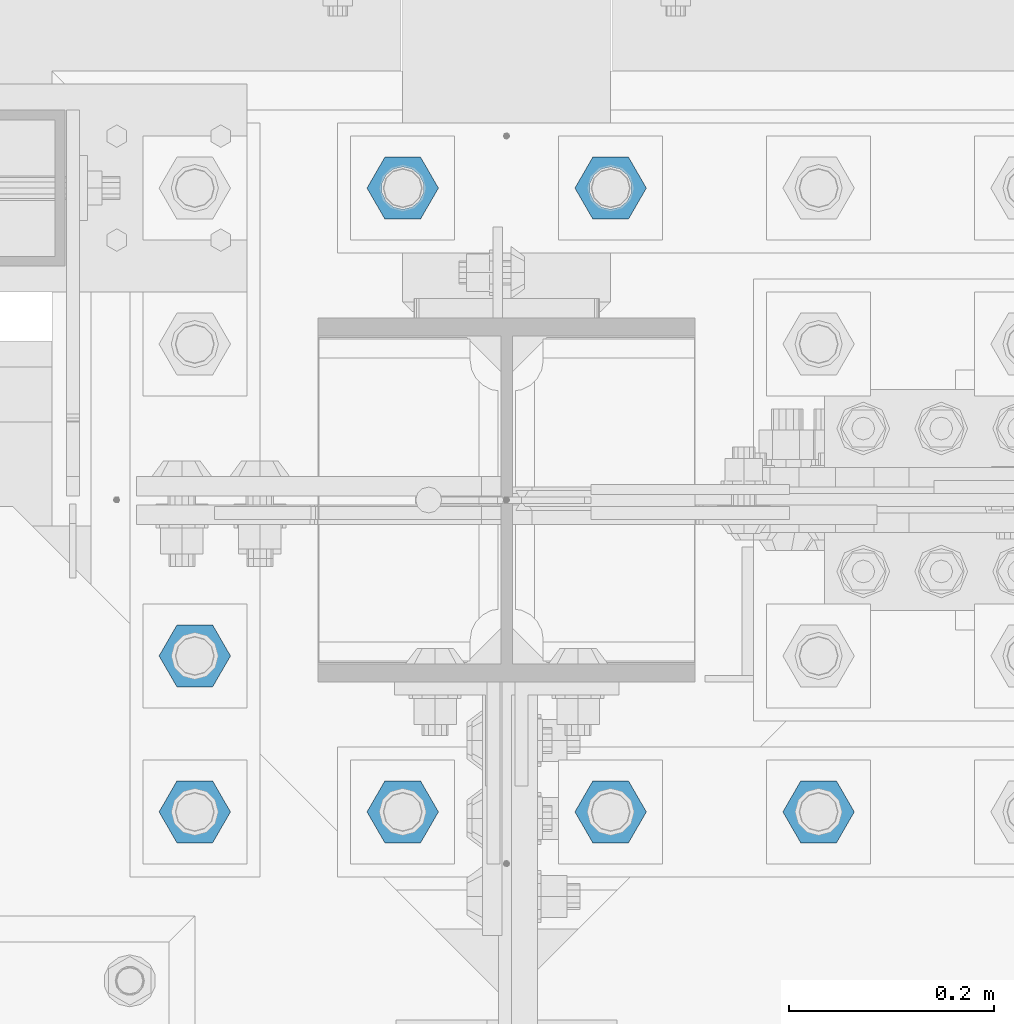
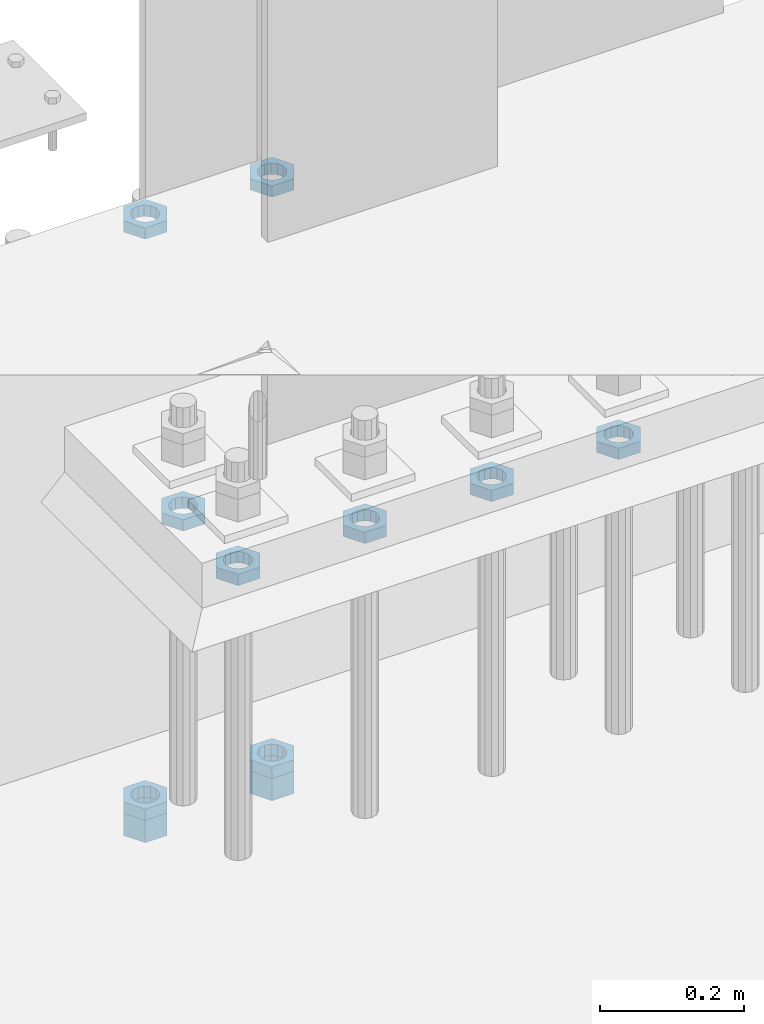
# One storey, part 2878 of 3843: 11 beams, 1 element without a shape of its own.
"""IFC2X3 building model written with IfcOpenShell, lengths in millimetres."""

from ifc_helpers import new_model, si_unit, frame, origin_with_axes, place, context, subcontext, project, spatial, faceted_brep, material, type_object, element, aggregate, save


model = new_model("IFC2X3")

# Units and contexts
model_context = context("Model", 3, precision=1e-05, world=origin_with_axes())
body_context = subcontext(model_context, "Body", "Model", "MODEL_VIEW")
ifc_project = project(units=[si_unit("LENGTHUNIT", "METRE", prefix="MILLI"), si_unit("AREAUNIT", "SQUARE_METRE"), si_unit("VOLUMEUNIT", "CUBIC_METRE"), si_unit("MASSUNIT", "GRAM", prefix="KILO"), si_unit("TIMEUNIT", "SECOND"), si_unit("PLANEANGLEUNIT", "RADIAN"), si_unit("SOLIDANGLEUNIT", "STERADIAN"), si_unit("THERMODYNAMICTEMPERATUREUNIT", "DEGREE_CELSIUS"), si_unit("LUMINOUSINTENSITYUNIT", "LUMEN")], contexts=[model_context])

# Site, building, storey
site_placement = place(None, origin_with_axes())
site = spatial("IfcSite", under=ifc_project, at=site_placement, CompositionType="ELEMENT")
building_placement = place(site_placement, origin_with_axes())
building = spatial("IfcBuilding", under=site, at=building_placement, Name="Undefined", CompositionType="ELEMENT")
storey_placement = place(building_placement, origin_with_axes())
storey = spatial("IfcBuildingStorey", under=building, at=storey_placement, Name="Undefined", CompositionType="ELEMENT", Elevation=0.0)

# Assembly, beams
assembly_placement = place(storey_placement, origin_with_axes())
assembly = element("IfcElementAssembly", 1, at=assembly_placement, inside=storey, Name="TEMPLATE", AssemblyPlace="NOTDEFINED", PredefinedType="RIGID_FRAME")
ifc_material = material(Name="STEEL/A572-50")
beam_type_1 = type_object("IfcBeamType", Name="1-1/2_HEAVY_HEX_NUT", PredefinedType="NOTDEFINED")
beam_1_placement = place(assembly_placement, frame((48895.0, 92519.5, 29203.6500015259), z_axis=(0.0, -1.0, 0.0), x_axis=(0.0, 0.0, -1.0)))
beam_1 = element("IfcBeam", 2, at=beam_1_placement, type_object=beam_type_1, material=ifc_material, Name="NUT", ObjectType="1-1/2_HEAVY_HEX_NUT", context=body_context, shape_type="Brep", body=[
    faceted_brep([(0.0, -34.9199981689453, 0.0), (0.0, -17.4599990844727, -30.25), (38.0999999999985, -17.4599990844727, -30.25), (38.0999999999985, -34.9199981689453, 0.0), (0.0, 17.4599990844727, -30.25), (38.0999999999985, 17.4599990844727, -30.25), (0.0, 34.9199981689453, 0.0), (38.0999999999985, 34.9199981689453, 0.0), (0.0, 17.4599990844727, 30.25), (38.0999999999985, 17.4599990844727, 30.25), (0.0, -17.4599990844727, 30.25), (38.0999999999985, -17.4599990844727, 30.25), (0.0, 0.0, 20.6399993896484), (0.0, 8.9553601105581, 18.5959968835959), (38.0999999999985, 8.9553601105581, 18.5959968835959), (38.0999999999985, 0.0, 20.6399993896484), (0.0, 16.1370013209525, 12.8688291298167), (38.0999999999985, 16.1370013209525, 12.8688291298167), (0.0, 20.1225115123816, 4.59283194104501), (38.0999999999985, 20.1225115123816, 4.59283194104501), (0.0, 20.1225115123816, -4.59283194104501), (38.0999999999985, 20.1225115123816, -4.59283194104501), (0.0, 16.1370013209525, -12.8688291298167), (38.0999999999985, 16.1370013209525, -12.8688291298167), (0.0, 8.9553601105581, -18.5959968835959), (38.0999999999985, 8.9553601105581, -18.5959968835959), (0.0, 0.0, -20.6399993896484), (38.0999999999985, 0.0, -20.6399993896484), (0.0, -8.9553601105581, -18.5959968835959), (38.0999999999985, -8.9553601105581, -18.5959968835959), (0.0, -16.1370013209525, -12.8688291298167), (38.0999999999985, -16.1370013209525, -12.8688291298167), (0.0, -20.1225115123816, -4.59283194104501), (38.0999999999985, -20.1225115123816, -4.59283194104501), (0.0, -20.1225115123816, 4.59283194104501), (38.0999999999985, -20.1225115123816, 4.59283194104501), (0.0, -16.1370013209525, 12.8688291298167), (38.0999999999985, -16.1370013209525, 12.8688291298167), (0.0, -8.9553601105581, 18.5959968835959), (38.0999999999985, -8.9553601105581, 18.5959968835959)], [[[0, 1, 2, 3]], [[1, 4, 5, 2]], [[4, 6, 7, 5]], [[6, 8, 9, 7]], [[8, 10, 11, 9]], [[10, 0, 3, 11]], [[12, 13, 14, 15]], [[13, 16, 17, 14]], [[16, 18, 19, 17]], [[18, 20, 21, 19]], [[20, 22, 23, 21]], [[22, 24, 25, 23]], [[24, 26, 27, 25]], [[26, 28, 29, 27]], [[28, 30, 31, 29]], [[30, 32, 33, 31]], [[32, 34, 35, 33]], [[34, 36, 37, 35]], [[36, 38, 39, 37]], [[38, 12, 15, 39]], [[5, 7, 9, 11, 3, 2], [17, 19, 21, 23, 25, 27, 29, 31, 33, 35, 37, 39, 15, 14]], [[10, 8, 6, 4, 1, 0], [38, 36, 34, 32, 30, 28, 26, 24, 22, 20, 18, 16, 13, 12]]]),
])
beam_2_placement = place(assembly_placement, frame((49098.2, 92519.5, 29203.6500015259), z_axis=(0.0, -1.0, 0.0), x_axis=(0.0, 0.0, -1.0)))
beam_2 = element("IfcBeam", 3, at=beam_2_placement, type_object=beam_type_1, material=ifc_material, Name="NUT", ObjectType="1-1/2_HEAVY_HEX_NUT", context=body_context, shape_type="Brep", body=[
    faceted_brep([(0.0, -34.9199981689453, 0.0), (0.0, -17.4599990844727, -30.25), (38.0999999999985, -17.4599990844727, -30.25), (38.0999999999985, -34.9199981689453, 0.0), (0.0, 17.4599990844727, -30.25), (38.0999999999985, 17.4599990844727, -30.25), (0.0, 34.9199981689453, 0.0), (38.0999999999985, 34.9199981689453, 0.0), (0.0, 17.4599990844727, 30.25), (38.0999999999985, 17.4599990844727, 30.25), (0.0, -17.4599990844727, 30.25), (38.0999999999985, -17.4599990844727, 30.25), (0.0, 0.0, 20.6399993896484), (0.0, 8.9553601105581, 18.5959968835959), (38.0999999999985, 8.9553601105581, 18.5959968835959), (38.0999999999985, 0.0, 20.6399993896484), (0.0, 16.1370013209525, 12.8688291298167), (38.0999999999985, 16.1370013209525, 12.8688291298167), (0.0, 20.1225115123816, 4.59283194104501), (38.0999999999985, 20.1225115123816, 4.59283194104501), (0.0, 20.1225115123816, -4.59283194104501), (38.0999999999985, 20.1225115123816, -4.59283194104501), (0.0, 16.1370013209525, -12.8688291298167), (38.0999999999985, 16.1370013209525, -12.8688291298167), (0.0, 8.9553601105581, -18.5959968835959), (38.0999999999985, 8.9553601105581, -18.5959968835959), (0.0, 0.0, -20.6399993896484), (38.0999999999985, 0.0, -20.6399993896484), (0.0, -8.9553601105581, -18.5959968835959), (38.0999999999985, -8.9553601105581, -18.5959968835959), (0.0, -16.1370013209525, -12.8688291298167), (38.0999999999985, -16.1370013209525, -12.8688291298167), (0.0, -20.1225115123816, -4.59283194104501), (38.0999999999985, -20.1225115123816, -4.59283194104501), (0.0, -20.1225115123816, 4.59283194104501), (38.0999999999985, -20.1225115123816, 4.59283194104501), (0.0, -16.1370013209525, 12.8688291298167), (38.0999999999985, -16.1370013209525, 12.8688291298167), (0.0, -8.9553601105581, 18.5959968835959), (38.0999999999985, -8.9553601105581, 18.5959968835959)], [[[0, 1, 2, 3]], [[1, 4, 5, 2]], [[4, 6, 7, 5]], [[6, 8, 9, 7]], [[8, 10, 11, 9]], [[10, 0, 3, 11]], [[12, 13, 14, 15]], [[13, 16, 17, 14]], [[16, 18, 19, 17]], [[18, 20, 21, 19]], [[20, 22, 23, 21]], [[22, 24, 25, 23]], [[24, 26, 27, 25]], [[26, 28, 29, 27]], [[28, 30, 31, 29]], [[30, 32, 33, 31]], [[32, 34, 35, 33]], [[34, 36, 37, 35]], [[36, 38, 39, 37]], [[38, 12, 15, 39]], [[5, 7, 9, 11, 3, 2], [17, 19, 21, 23, 25, 27, 29, 31, 33, 35, 37, 39, 15, 14]], [[10, 8, 6, 4, 1, 0], [38, 36, 34, 32, 30, 28, 26, 24, 22, 20, 18, 16, 13, 12]]]),
])
beam_type_2 = type_object("IfcBeamType", Name="1-1/2_HALF_NUT", PredefinedType="NOTDEFINED")
beam_3_placement = place(assembly_placement, frame((48691.800012207, 92062.3, 30060.9), z_axis=(0.0, -1.0, 0.0), x_axis=(0.0, 0.0, -1.0)))
beam_3 = element("IfcBeam", 4, at=beam_3_placement, type_object=beam_type_2, material=ifc_material, Name="NUT", ObjectType="1-1/2_HALF_NUT", context=body_context, shape_type="Brep", body=[
    faceted_brep([(0.0, -34.9199981689453, 0.0), (0.0, -17.4599990844727, -30.25), (19.0500000000029, -17.4599990844727, -30.25), (19.0500000000029, -34.9199981689453, 0.0), (0.0, 17.4599990844727, -30.25), (19.0500000000029, 17.4599990844727, -30.25), (0.0, 34.9199981689453, 0.0), (19.0500000000029, 34.9199981689453, 0.0), (0.0, 17.4599990844727, 30.25), (19.0500000000029, 17.4599990844727, 30.25), (0.0, -17.4599990844727, 30.25), (19.0500000000029, -17.4599990844727, 30.25), (0.0, 0.0, 20.6399993896484), (0.0, 8.9553601105581, 18.5959968835959), (19.0500000000029, 8.95536011056538, 18.5959968835959), (19.0500000000029, 0.0, 20.6399993896484), (0.0, 16.1370013209525, 12.8688291298167), (19.0500000000029, 16.1370013209489, 12.8688291298167), (0.0, 20.1225115123816, 4.59283194104501), (19.0500000000029, 20.1225115123852, 4.59283194104501), (0.0, 20.1225115123816, -4.59283194104501), (19.0500000000029, 20.1225115123852, -4.59283194104501), (0.0, 16.1370013209525, -12.8688291298167), (19.0500000000029, 16.1370013209489, -12.8688291298167), (0.0, 8.9553601105581, -18.5959968835959), (19.0500000000029, 8.95536011056538, -18.5959968835959), (0.0, 0.0, -20.6399993896484), (19.0500000000029, 0.0, -20.6399993896484), (0.0, -8.9553601105581, -18.5959968835959), (19.0500000000029, -8.95536011056538, -18.5959968835959), (0.0, -16.1370013209525, -12.8688291298167), (19.0500000000029, -16.1370013209489, -12.8688291298167), (0.0, -20.1225115123816, -4.59283194104501), (19.0500000000029, -20.1225115123852, -4.59283194104501), (0.0, -20.1225115123816, 4.59283194104501), (19.0500000000029, -20.1225115123852, 4.59283194104501), (0.0, -16.1370013209525, 12.8688291298167), (19.0500000000029, -16.1370013209489, 12.8688291298167), (0.0, -8.9553601105581, 18.5959968835959), (19.0500000000029, -8.95536011056538, 18.5959968835959)], [[[0, 1, 2, 3]], [[1, 4, 5, 2]], [[4, 6, 7, 5]], [[6, 8, 9, 7]], [[8, 10, 11, 9]], [[10, 0, 3, 11]], [[12, 13, 14, 15]], [[13, 16, 17, 14]], [[16, 18, 19, 17]], [[18, 20, 21, 19]], [[20, 22, 23, 21]], [[22, 24, 25, 23]], [[24, 26, 27, 25]], [[26, 28, 29, 27]], [[28, 30, 31, 29]], [[30, 32, 33, 31]], [[32, 34, 35, 33]], [[34, 36, 37, 35]], [[36, 38, 39, 37]], [[38, 12, 15, 39]], [[5, 7, 9, 11, 3, 2], [17, 19, 21, 23, 25, 27, 29, 31, 33, 35, 37, 39, 15, 14]], [[10, 8, 6, 4, 1, 0], [38, 36, 34, 32, 30, 28, 26, 24, 22, 20, 18, 16, 13, 12]]]),
])
beam_4_placement = place(assembly_placement, frame((48691.800012207, 91909.9, 30060.9), z_axis=(0.0, -1.0, 0.0), x_axis=(0.0, 0.0, -1.0)))
beam_4 = element("IfcBeam", 5, at=beam_4_placement, type_object=beam_type_2, material=ifc_material, Name="NUT", ObjectType="1-1/2_HALF_NUT", context=body_context, shape_type="Brep", body=[
    faceted_brep([(0.0, -34.9199981689453, 0.0), (0.0, -17.4599990844727, -30.25), (19.0500000000029, -17.4599990844727, -30.25), (19.0500000000029, -34.9199981689453, 0.0), (0.0, 17.4599990844727, -30.25), (19.0500000000029, 17.4599990844727, -30.25), (0.0, 34.9199981689453, 0.0), (19.0500000000029, 34.9199981689453, 0.0), (0.0, 17.4599990844727, 30.25), (19.0500000000029, 17.4599990844727, 30.25), (0.0, -17.4599990844727, 30.25), (19.0500000000029, -17.4599990844727, 30.25), (0.0, 0.0, 20.6399993896484), (0.0, 8.9553601105581, 18.5959968835959), (19.0500000000029, 8.95536011056538, 18.5959968835959), (19.0500000000029, 0.0, 20.6399993896484), (0.0, 16.1370013209525, 12.8688291298167), (19.0500000000029, 16.1370013209489, 12.8688291298167), (0.0, 20.1225115123816, 4.59283194104501), (19.0500000000029, 20.1225115123852, 4.59283194104501), (0.0, 20.1225115123816, -4.59283194104501), (19.0500000000029, 20.1225115123852, -4.59283194104501), (0.0, 16.1370013209525, -12.8688291298167), (19.0500000000029, 16.1370013209489, -12.8688291298167), (0.0, 8.9553601105581, -18.5959968835959), (19.0500000000029, 8.95536011056538, -18.5959968835959), (0.0, 0.0, -20.6399993896484), (19.0500000000029, 0.0, -20.6399993896484), (0.0, -8.9553601105581, -18.5959968835959), (19.0500000000029, -8.95536011056538, -18.5959968835959), (0.0, -16.1370013209525, -12.8688291298167), (19.0500000000029, -16.1370013209489, -12.8688291298167), (0.0, -20.1225115123816, -4.59283194104501), (19.0500000000029, -20.1225115123852, -4.59283194104501), (0.0, -20.1225115123816, 4.59283194104501), (19.0500000000029, -20.1225115123852, 4.59283194104501), (0.0, -16.1370013209525, 12.8688291298167), (19.0500000000029, -16.1370013209489, 12.8688291298167), (0.0, -8.9553601105581, 18.5959968835959), (19.0500000000029, -8.95536011056538, 18.5959968835959)], [[[0, 1, 2, 3]], [[1, 4, 5, 2]], [[4, 6, 7, 5]], [[6, 8, 9, 7]], [[8, 10, 11, 9]], [[10, 0, 3, 11]], [[12, 13, 14, 15]], [[13, 16, 17, 14]], [[16, 18, 19, 17]], [[18, 20, 21, 19]], [[20, 22, 23, 21]], [[22, 24, 25, 23]], [[24, 26, 27, 25]], [[26, 28, 29, 27]], [[28, 30, 31, 29]], [[30, 32, 33, 31]], [[32, 34, 35, 33]], [[34, 36, 37, 35]], [[36, 38, 39, 37]], [[38, 12, 15, 39]], [[5, 7, 9, 11, 3, 2], [17, 19, 21, 23, 25, 27, 29, 31, 33, 35, 37, 39, 15, 14]], [[10, 8, 6, 4, 1, 0], [38, 36, 34, 32, 30, 28, 26, 24, 22, 20, 18, 16, 13, 12]]]),
])
beam_5_placement = place(assembly_placement, frame((48895.000012207, 91909.9, 30060.9), z_axis=(0.0, -1.0, 0.0), x_axis=(0.0, 0.0, -1.0)))
beam_5 = element("IfcBeam", 6, at=beam_5_placement, type_object=beam_type_2, material=ifc_material, Name="NUT", ObjectType="1-1/2_HALF_NUT", context=body_context, shape_type="Brep", body=[
    faceted_brep([(0.0, -34.9199981689453, 0.0), (0.0, -17.4599990844727, -30.25), (19.0500000000029, -17.4599990844727, -30.25), (19.0500000000029, -34.9199981689453, 0.0), (0.0, 17.4599990844727, -30.25), (19.0500000000029, 17.4599990844727, -30.25), (0.0, 34.9199981689453, 0.0), (19.0500000000029, 34.9199981689453, 0.0), (0.0, 17.4599990844727, 30.25), (19.0500000000029, 17.4599990844727, 30.25), (0.0, -17.4599990844727, 30.25), (19.0500000000029, -17.4599990844727, 30.25), (0.0, 0.0, 20.6399993896484), (0.0, 8.9553601105581, 18.5959968835959), (19.0500000000029, 8.95536011056538, 18.5959968835959), (19.0500000000029, 0.0, 20.6399993896484), (0.0, 16.1370013209525, 12.8688291298167), (19.0500000000029, 16.1370013209489, 12.8688291298167), (0.0, 20.1225115123816, 4.59283194104501), (19.0500000000029, 20.1225115123852, 4.59283194104501), (0.0, 20.1225115123816, -4.59283194104501), (19.0500000000029, 20.1225115123852, -4.59283194104501), (0.0, 16.1370013209525, -12.8688291298167), (19.0500000000029, 16.1370013209489, -12.8688291298167), (0.0, 8.9553601105581, -18.5959968835959), (19.0500000000029, 8.95536011056538, -18.5959968835959), (0.0, 0.0, -20.6399993896484), (19.0500000000029, 0.0, -20.6399993896484), (0.0, -8.9553601105581, -18.5959968835959), (19.0500000000029, -8.95536011056538, -18.5959968835959), (0.0, -16.1370013209525, -12.8688291298167), (19.0500000000029, -16.1370013209489, -12.8688291298167), (0.0, -20.1225115123816, -4.59283194104501), (19.0500000000029, -20.1225115123852, -4.59283194104501), (0.0, -20.1225115123816, 4.59283194104501), (19.0500000000029, -20.1225115123852, 4.59283194104501), (0.0, -16.1370013209525, 12.8688291298167), (19.0500000000029, -16.1370013209489, 12.8688291298167), (0.0, -8.9553601105581, 18.5959968835959), (19.0500000000029, -8.95536011056538, 18.5959968835959)], [[[0, 1, 2, 3]], [[1, 4, 5, 2]], [[4, 6, 7, 5]], [[6, 8, 9, 7]], [[8, 10, 11, 9]], [[10, 0, 3, 11]], [[12, 13, 14, 15]], [[13, 16, 17, 14]], [[16, 18, 19, 17]], [[18, 20, 21, 19]], [[20, 22, 23, 21]], [[22, 24, 25, 23]], [[24, 26, 27, 25]], [[26, 28, 29, 27]], [[28, 30, 31, 29]], [[30, 32, 33, 31]], [[32, 34, 35, 33]], [[34, 36, 37, 35]], [[36, 38, 39, 37]], [[38, 12, 15, 39]], [[5, 7, 9, 11, 3, 2], [17, 19, 21, 23, 25, 27, 29, 31, 33, 35, 37, 39, 15, 14]], [[10, 8, 6, 4, 1, 0], [38, 36, 34, 32, 30, 28, 26, 24, 22, 20, 18, 16, 13, 12]]]),
])
beam_6_placement = place(assembly_placement, frame((49098.200012207, 91909.9, 30060.9), z_axis=(0.0, -1.0, 0.0), x_axis=(0.0, 0.0, -1.0)))
beam_6 = element("IfcBeam", 7, at=beam_6_placement, type_object=beam_type_2, material=ifc_material, Name="NUT", ObjectType="1-1/2_HALF_NUT", context=body_context, shape_type="Brep", body=[
    faceted_brep([(0.0, -34.9199981689453, 0.0), (0.0, -17.4599990844727, -30.25), (19.0500000000029, -17.4599990844727, -30.25), (19.0500000000029, -34.9199981689453, 0.0), (0.0, 17.4599990844727, -30.25), (19.0500000000029, 17.4599990844727, -30.25), (0.0, 34.9199981689453, 0.0), (19.0500000000029, 34.9199981689453, 0.0), (0.0, 17.4599990844727, 30.25), (19.0500000000029, 17.4599990844727, 30.25), (0.0, -17.4599990844727, 30.25), (19.0500000000029, -17.4599990844727, 30.25), (0.0, 0.0, 20.6399993896484), (0.0, 8.9553601105581, 18.5959968835959), (19.0500000000029, 8.95536011056538, 18.5959968835959), (19.0500000000029, 0.0, 20.6399993896484), (0.0, 16.1370013209525, 12.8688291298167), (19.0500000000029, 16.1370013209489, 12.8688291298167), (0.0, 20.1225115123816, 4.59283194104501), (19.0500000000029, 20.1225115123852, 4.59283194104501), (0.0, 20.1225115123816, -4.59283194104501), (19.0500000000029, 20.1225115123852, -4.59283194104501), (0.0, 16.1370013209525, -12.8688291298167), (19.0500000000029, 16.1370013209489, -12.8688291298167), (0.0, 8.9553601105581, -18.5959968835959), (19.0500000000029, 8.95536011056538, -18.5959968835959), (0.0, 0.0, -20.6399993896484), (19.0500000000029, 0.0, -20.6399993896484), (0.0, -8.9553601105581, -18.5959968835959), (19.0500000000029, -8.95536011056538, -18.5959968835959), (0.0, -16.1370013209525, -12.8688291298167), (19.0500000000029, -16.1370013209489, -12.8688291298167), (0.0, -20.1225115123816, -4.59283194104501), (19.0500000000029, -20.1225115123852, -4.59283194104501), (0.0, -20.1225115123816, 4.59283194104501), (19.0500000000029, -20.1225115123852, 4.59283194104501), (0.0, -16.1370013209525, 12.8688291298167), (19.0500000000029, -16.1370013209489, 12.8688291298167), (0.0, -8.9553601105581, 18.5959968835959), (19.0500000000029, -8.95536011056538, 18.5959968835959)], [[[0, 1, 2, 3]], [[1, 4, 5, 2]], [[4, 6, 7, 5]], [[6, 8, 9, 7]], [[8, 10, 11, 9]], [[10, 0, 3, 11]], [[12, 13, 14, 15]], [[13, 16, 17, 14]], [[16, 18, 19, 17]], [[18, 20, 21, 19]], [[20, 22, 23, 21]], [[22, 24, 25, 23]], [[24, 26, 27, 25]], [[26, 28, 29, 27]], [[28, 30, 31, 29]], [[30, 32, 33, 31]], [[32, 34, 35, 33]], [[34, 36, 37, 35]], [[36, 38, 39, 37]], [[38, 12, 15, 39]], [[5, 7, 9, 11, 3, 2], [17, 19, 21, 23, 25, 27, 29, 31, 33, 35, 37, 39, 15, 14]], [[10, 8, 6, 4, 1, 0], [38, 36, 34, 32, 30, 28, 26, 24, 22, 20, 18, 16, 13, 12]]]),
])
beam_7_placement = place(assembly_placement, frame((49301.400012207, 91909.9, 30060.9), z_axis=(0.0, 1.0, 0.0), x_axis=(0.0, 0.0, -1.0)))
beam_7 = element("IfcBeam", 8, at=beam_7_placement, type_object=beam_type_2, material=ifc_material, Name="NUT", ObjectType="1-1/2_HALF_NUT", context=body_context, shape_type="Brep", body=[
    faceted_brep([(0.0, -34.9199981689453, 0.0), (0.0, -17.4599990844727, -30.25), (19.0500000000029, -17.4599990844727, -30.25), (19.0500000000029, -34.9199981689453, 0.0), (0.0, 17.4599990844727, -30.25), (19.0500000000029, 17.4599990844727, -30.25), (0.0, 34.9199981689453, 0.0), (19.0500000000029, 34.9199981689453, 0.0), (0.0, 17.4599990844727, 30.25), (19.0500000000029, 17.4599990844727, 30.25), (0.0, -17.4599990844727, 30.25), (19.0500000000029, -17.4599990844727, 30.25), (0.0, 0.0, 20.6399993896484), (0.0, 8.9553601105581, 18.5959968835959), (19.0500000000029, 8.95536011056538, 18.5959968835959), (19.0500000000029, 0.0, 20.6399993896484), (0.0, 16.1370013209525, 12.8688291298167), (19.0500000000029, 16.1370013209489, 12.8688291298167), (0.0, 20.1225115123816, 4.59283194104501), (19.0500000000029, 20.1225115123852, 4.59283194104501), (0.0, 20.1225115123816, -4.59283194104501), (19.0500000000029, 20.1225115123852, -4.59283194104501), (0.0, 16.1370013209525, -12.8688291298167), (19.0500000000029, 16.1370013209489, -12.8688291298167), (0.0, 8.9553601105581, -18.5959968835959), (19.0500000000029, 8.95536011056538, -18.5959968835959), (0.0, 0.0, -20.6399993896484), (19.0500000000029, 0.0, -20.6399993896484), (0.0, -8.9553601105581, -18.5959968835959), (19.0500000000029, -8.95536011056538, -18.5959968835959), (0.0, -16.1370013209525, -12.8688291298167), (19.0500000000029, -16.1370013209489, -12.8688291298167), (0.0, -20.1225115123816, -4.59283194104501), (19.0500000000029, -20.1225115123852, -4.59283194104501), (0.0, -20.1225115123816, 4.59283194104501), (19.0500000000029, -20.1225115123852, 4.59283194104501), (0.0, -16.1370013209525, 12.8688291298167), (19.0500000000029, -16.1370013209489, 12.8688291298167), (0.0, -8.9553601105581, 18.5959968835959), (19.0500000000029, -8.95536011056538, 18.5959968835959)], [[[0, 1, 2, 3]], [[1, 4, 5, 2]], [[4, 6, 7, 5]], [[6, 8, 9, 7]], [[8, 10, 11, 9]], [[10, 0, 3, 11]], [[12, 13, 14, 15]], [[13, 16, 17, 14]], [[16, 18, 19, 17]], [[18, 20, 21, 19]], [[20, 22, 23, 21]], [[22, 24, 25, 23]], [[24, 26, 27, 25]], [[26, 28, 29, 27]], [[28, 30, 31, 29]], [[30, 32, 33, 31]], [[32, 34, 35, 33]], [[34, 36, 37, 35]], [[36, 38, 39, 37]], [[38, 12, 15, 39]], [[5, 7, 9, 11, 3, 2], [17, 19, 21, 23, 25, 27, 29, 31, 33, 35, 37, 39, 15, 14]], [[10, 8, 6, 4, 1, 0], [38, 36, 34, 32, 30, 28, 26, 24, 22, 20, 18, 16, 13, 12]]]),
])
beam_8_placement = place(assembly_placement, frame((48895.0, 92519.5, 29222.7000015259), z_axis=(0.0, -1.0, 0.0), x_axis=(0.0, 0.0, -1.0)))
beam_8 = element("IfcBeam", 9, at=beam_8_placement, type_object=beam_type_2, material=ifc_material, Name="NUT", ObjectType="1-1/2_HALF_NUT", context=body_context, shape_type="Brep", body=[
    faceted_brep([(0.0, -34.9199981689453, 0.0), (0.0, -17.4599990844727, -30.25), (19.0500000000029, -17.4599990844727, -30.25), (19.0500000000029, -34.9199981689453, 0.0), (0.0, 17.4599990844727, -30.25), (19.0500000000029, 17.4599990844727, -30.25), (0.0, 34.9199981689453, 0.0), (19.0500000000029, 34.9199981689453, 0.0), (0.0, 17.4599990844727, 30.25), (19.0500000000029, 17.4599990844727, 30.25), (0.0, -17.4599990844727, 30.25), (19.0500000000029, -17.4599990844727, 30.25), (0.0, 0.0, 20.6399993896484), (0.0, 8.9553601105581, 18.5959968835959), (19.0500000000029, 8.95536011056538, 18.5959968835959), (19.0500000000029, 0.0, 20.6399993896484), (0.0, 16.1370013209525, 12.8688291298167), (19.0500000000029, 16.1370013209489, 12.8688291298167), (0.0, 20.1225115123816, 4.59283194104501), (19.0500000000029, 20.1225115123852, 4.59283194104501), (0.0, 20.1225115123816, -4.59283194104501), (19.0500000000029, 20.1225115123852, -4.59283194104501), (0.0, 16.1370013209525, -12.8688291298167), (19.0500000000029, 16.1370013209489, -12.8688291298167), (0.0, 8.9553601105581, -18.5959968835959), (19.0500000000029, 8.95536011056538, -18.5959968835959), (0.0, 0.0, -20.6399993896484), (19.0500000000029, 0.0, -20.6399993896484), (0.0, -8.9553601105581, -18.5959968835959), (19.0500000000029, -8.95536011056538, -18.5959968835959), (0.0, -16.1370013209525, -12.8688291298167), (19.0500000000029, -16.1370013209489, -12.8688291298167), (0.0, -20.1225115123816, -4.59283194104501), (19.0500000000029, -20.1225115123852, -4.59283194104501), (0.0, -20.1225115123816, 4.59283194104501), (19.0500000000029, -20.1225115123852, 4.59283194104501), (0.0, -16.1370013209525, 12.8688291298167), (19.0500000000029, -16.1370013209489, 12.8688291298167), (0.0, -8.9553601105581, 18.5959968835959), (19.0500000000029, -8.95536011056538, 18.5959968835959)], [[[0, 1, 2, 3]], [[1, 4, 5, 2]], [[4, 6, 7, 5]], [[6, 8, 9, 7]], [[8, 10, 11, 9]], [[10, 0, 3, 11]], [[12, 13, 14, 15]], [[13, 16, 17, 14]], [[16, 18, 19, 17]], [[18, 20, 21, 19]], [[20, 22, 23, 21]], [[22, 24, 25, 23]], [[24, 26, 27, 25]], [[26, 28, 29, 27]], [[28, 30, 31, 29]], [[30, 32, 33, 31]], [[32, 34, 35, 33]], [[34, 36, 37, 35]], [[36, 38, 39, 37]], [[38, 12, 15, 39]], [[5, 7, 9, 11, 3, 2], [17, 19, 21, 23, 25, 27, 29, 31, 33, 35, 37, 39, 15, 14]], [[10, 8, 6, 4, 1, 0], [38, 36, 34, 32, 30, 28, 26, 24, 22, 20, 18, 16, 13, 12]]]),
])
beam_9_placement = place(assembly_placement, frame((48895.0, 92519.5, 30206.95), z_axis=(0.0, -1.0, 0.0), x_axis=(0.0, 0.0, -1.0)))
beam_9 = element("IfcBeam", 10, at=beam_9_placement, type_object=beam_type_2, material=ifc_material, Name="NUT", ObjectType="1-1/2_HALF_NUT", context=body_context, shape_type="Brep", body=[
    faceted_brep([(0.0, -34.9199981689453, 0.0), (0.0, -17.4599990844727, -30.25), (19.0500000000029, -17.4599990844727, -30.25), (19.0500000000029, -34.9199981689453, 0.0), (0.0, 17.4599990844727, -30.25), (19.0500000000029, 17.4599990844727, -30.25), (0.0, 34.9199981689453, 0.0), (19.0500000000029, 34.9199981689453, 0.0), (0.0, 17.4599990844727, 30.25), (19.0500000000029, 17.4599990844727, 30.25), (0.0, -17.4599990844727, 30.25), (19.0500000000029, -17.4599990844727, 30.25), (0.0, 0.0, 20.6399993896484), (0.0, 8.9553601105581, 18.5959968835959), (19.0500000000029, 8.95536011056538, 18.5959968835959), (19.0500000000029, 0.0, 20.6399993896484), (0.0, 16.1370013209525, 12.8688291298167), (19.0500000000029, 16.1370013209489, 12.8688291298167), (0.0, 20.1225115123816, 4.59283194104501), (19.0500000000029, 20.1225115123852, 4.59283194104501), (0.0, 20.1225115123816, -4.59283194104501), (19.0500000000029, 20.1225115123852, -4.59283194104501), (0.0, 16.1370013209525, -12.8688291298167), (19.0500000000029, 16.1370013209489, -12.8688291298167), (0.0, 8.9553601105581, -18.5959968835959), (19.0500000000029, 8.95536011056538, -18.5959968835959), (0.0, 0.0, -20.6399993896484), (19.0500000000029, 0.0, -20.6399993896484), (0.0, -8.9553601105581, -18.5959968835959), (19.0500000000029, -8.95536011056538, -18.5959968835959), (0.0, -16.1370013209525, -12.8688291298167), (19.0500000000029, -16.1370013209489, -12.8688291298167), (0.0, -20.1225115123816, -4.59283194104501), (19.0500000000029, -20.1225115123852, -4.59283194104501), (0.0, -20.1225115123816, 4.59283194104501), (19.0500000000029, -20.1225115123852, 4.59283194104501), (0.0, -16.1370013209525, 12.8688291298167), (19.0500000000029, -16.1370013209489, 12.8688291298167), (0.0, -8.9553601105581, 18.5959968835959), (19.0500000000029, -8.95536011056538, 18.5959968835959)], [[[0, 1, 2, 3]], [[1, 4, 5, 2]], [[4, 6, 7, 5]], [[6, 8, 9, 7]], [[8, 10, 11, 9]], [[10, 0, 3, 11]], [[12, 13, 14, 15]], [[13, 16, 17, 14]], [[16, 18, 19, 17]], [[18, 20, 21, 19]], [[20, 22, 23, 21]], [[22, 24, 25, 23]], [[24, 26, 27, 25]], [[26, 28, 29, 27]], [[28, 30, 31, 29]], [[30, 32, 33, 31]], [[32, 34, 35, 33]], [[34, 36, 37, 35]], [[36, 38, 39, 37]], [[38, 12, 15, 39]], [[5, 7, 9, 11, 3, 2], [17, 19, 21, 23, 25, 27, 29, 31, 33, 35, 37, 39, 15, 14]], [[10, 8, 6, 4, 1, 0], [38, 36, 34, 32, 30, 28, 26, 24, 22, 20, 18, 16, 13, 12]]]),
])
beam_10_placement = place(assembly_placement, frame((49098.2, 92519.5, 29222.7000015259), z_axis=(0.0, -1.0, 0.0), x_axis=(0.0, 0.0, -1.0)))
beam_10 = element("IfcBeam", 11, at=beam_10_placement, type_object=beam_type_2, material=ifc_material, Name="NUT", ObjectType="1-1/2_HALF_NUT", context=body_context, shape_type="Brep", body=[
    faceted_brep([(0.0, -34.9199981689453, 0.0), (0.0, -17.4599990844727, -30.25), (19.0500000000029, -17.4599990844727, -30.25), (19.0500000000029, -34.9199981689453, 0.0), (0.0, 17.4599990844727, -30.25), (19.0500000000029, 17.4599990844727, -30.25), (0.0, 34.9199981689453, 0.0), (19.0500000000029, 34.9199981689453, 0.0), (0.0, 17.4599990844727, 30.25), (19.0500000000029, 17.4599990844727, 30.25), (0.0, -17.4599990844727, 30.25), (19.0500000000029, -17.4599990844727, 30.25), (0.0, 0.0, 20.6399993896484), (0.0, 8.9553601105581, 18.5959968835959), (19.0500000000029, 8.95536011056538, 18.5959968835959), (19.0500000000029, 0.0, 20.6399993896484), (0.0, 16.1370013209525, 12.8688291298167), (19.0500000000029, 16.1370013209489, 12.8688291298167), (0.0, 20.1225115123816, 4.59283194104501), (19.0500000000029, 20.1225115123852, 4.59283194104501), (0.0, 20.1225115123816, -4.59283194104501), (19.0500000000029, 20.1225115123852, -4.59283194104501), (0.0, 16.1370013209525, -12.8688291298167), (19.0500000000029, 16.1370013209489, -12.8688291298167), (0.0, 8.9553601105581, -18.5959968835959), (19.0500000000029, 8.95536011056538, -18.5959968835959), (0.0, 0.0, -20.6399993896484), (19.0500000000029, 0.0, -20.6399993896484), (0.0, -8.9553601105581, -18.5959968835959), (19.0500000000029, -8.95536011056538, -18.5959968835959), (0.0, -16.1370013209525, -12.8688291298167), (19.0500000000029, -16.1370013209489, -12.8688291298167), (0.0, -20.1225115123816, -4.59283194104501), (19.0500000000029, -20.1225115123852, -4.59283194104501), (0.0, -20.1225115123816, 4.59283194104501), (19.0500000000029, -20.1225115123852, 4.59283194104501), (0.0, -16.1370013209525, 12.8688291298167), (19.0500000000029, -16.1370013209489, 12.8688291298167), (0.0, -8.9553601105581, 18.5959968835959), (19.0500000000029, -8.95536011056538, 18.5959968835959)], [[[0, 1, 2, 3]], [[1, 4, 5, 2]], [[4, 6, 7, 5]], [[6, 8, 9, 7]], [[8, 10, 11, 9]], [[10, 0, 3, 11]], [[12, 13, 14, 15]], [[13, 16, 17, 14]], [[16, 18, 19, 17]], [[18, 20, 21, 19]], [[20, 22, 23, 21]], [[22, 24, 25, 23]], [[24, 26, 27, 25]], [[26, 28, 29, 27]], [[28, 30, 31, 29]], [[30, 32, 33, 31]], [[32, 34, 35, 33]], [[34, 36, 37, 35]], [[36, 38, 39, 37]], [[38, 12, 15, 39]], [[5, 7, 9, 11, 3, 2], [17, 19, 21, 23, 25, 27, 29, 31, 33, 35, 37, 39, 15, 14]], [[10, 8, 6, 4, 1, 0], [38, 36, 34, 32, 30, 28, 26, 24, 22, 20, 18, 16, 13, 12]]]),
])
beam_11_placement = place(assembly_placement, frame((49098.2, 92519.5, 30206.95), z_axis=(0.0, -1.0, 0.0), x_axis=(0.0, 0.0, -1.0)))
beam_11 = element("IfcBeam", 12, at=beam_11_placement, type_object=beam_type_2, material=ifc_material, Name="NUT", ObjectType="1-1/2_HALF_NUT", context=body_context, shape_type="Brep", body=[
    faceted_brep([(0.0, -34.9199981689453, 0.0), (0.0, -17.4599990844727, -30.25), (19.0500000000029, -17.4599990844727, -30.25), (19.0500000000029, -34.9199981689453, 0.0), (0.0, 17.4599990844727, -30.25), (19.0500000000029, 17.4599990844727, -30.25), (0.0, 34.9199981689453, 0.0), (19.0500000000029, 34.9199981689453, 0.0), (0.0, 17.4599990844727, 30.25), (19.0500000000029, 17.4599990844727, 30.25), (0.0, -17.4599990844727, 30.25), (19.0500000000029, -17.4599990844727, 30.25), (0.0, 0.0, 20.6399993896484), (0.0, 8.9553601105581, 18.5959968835959), (19.0500000000029, 8.95536011056538, 18.5959968835959), (19.0500000000029, 0.0, 20.6399993896484), (0.0, 16.1370013209525, 12.8688291298167), (19.0500000000029, 16.1370013209489, 12.8688291298167), (0.0, 20.1225115123816, 4.59283194104501), (19.0500000000029, 20.1225115123852, 4.59283194104501), (0.0, 20.1225115123816, -4.59283194104501), (19.0500000000029, 20.1225115123852, -4.59283194104501), (0.0, 16.1370013209525, -12.8688291298167), (19.0500000000029, 16.1370013209489, -12.8688291298167), (0.0, 8.9553601105581, -18.5959968835959), (19.0500000000029, 8.95536011056538, -18.5959968835959), (0.0, 0.0, -20.6399993896484), (19.0500000000029, 0.0, -20.6399993896484), (0.0, -8.9553601105581, -18.5959968835959), (19.0500000000029, -8.95536011056538, -18.5959968835959), (0.0, -16.1370013209525, -12.8688291298167), (19.0500000000029, -16.1370013209489, -12.8688291298167), (0.0, -20.1225115123816, -4.59283194104501), (19.0500000000029, -20.1225115123852, -4.59283194104501), (0.0, -20.1225115123816, 4.59283194104501), (19.0500000000029, -20.1225115123852, 4.59283194104501), (0.0, -16.1370013209525, 12.8688291298167), (19.0500000000029, -16.1370013209489, 12.8688291298167), (0.0, -8.9553601105581, 18.5959968835959), (19.0500000000029, -8.95536011056538, 18.5959968835959)], [[[0, 1, 2, 3]], [[1, 4, 5, 2]], [[4, 6, 7, 5]], [[6, 8, 9, 7]], [[8, 10, 11, 9]], [[10, 0, 3, 11]], [[12, 13, 14, 15]], [[13, 16, 17, 14]], [[16, 18, 19, 17]], [[18, 20, 21, 19]], [[20, 22, 23, 21]], [[22, 24, 25, 23]], [[24, 26, 27, 25]], [[26, 28, 29, 27]], [[28, 30, 31, 29]], [[30, 32, 33, 31]], [[32, 34, 35, 33]], [[34, 36, 37, 35]], [[36, 38, 39, 37]], [[38, 12, 15, 39]], [[5, 7, 9, 11, 3, 2], [17, 19, 21, 23, 25, 27, 29, 31, 33, 35, 37, 39, 15, 14]], [[10, 8, 6, 4, 1, 0], [38, 36, 34, 32, 30, 28, 26, 24, 22, 20, 18, 16, 13, 12]]]),
])
aggregate(assembly, [beam_3, beam_4, beam_5, beam_6, beam_7, beam_8, beam_1, beam_9, beam_10, beam_2, beam_11])

save(model, "model.ifc")
